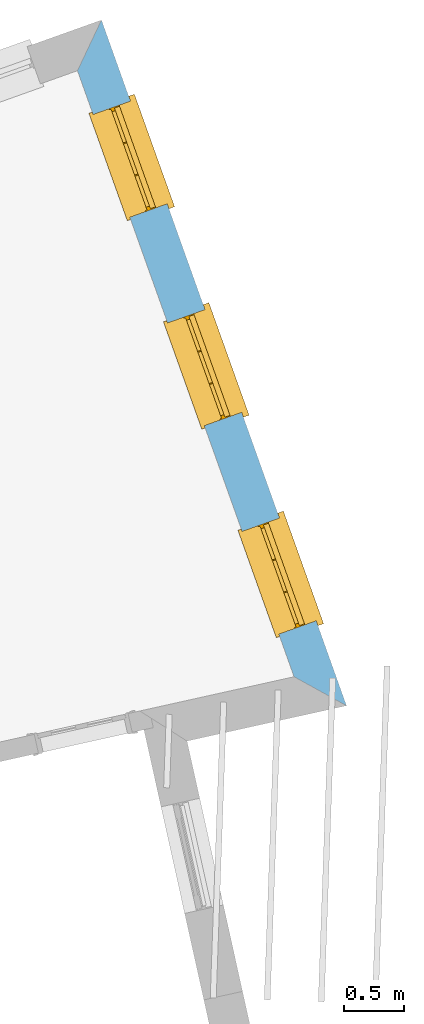
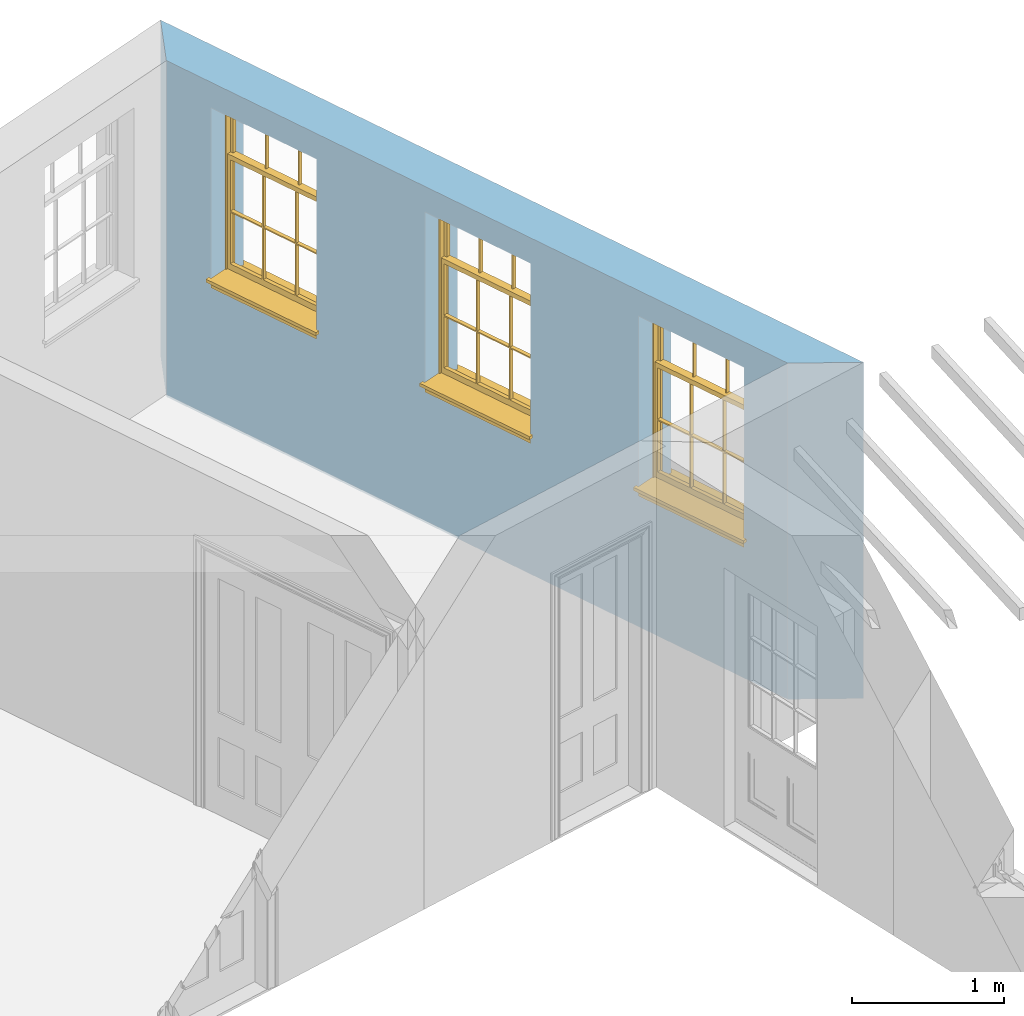
# One storey, part 9 of 11: 3 windows, 3 openings, plus 1 element that does not belong to this part.
"""IFC2X3 building model written with IfcOpenShell, lengths in metres."""

from ifc_helpers import new_model, si_unit, frame, origin, place, context, subcontext, project, spatial, polyline, outline, extrude, faceted_brep, material, layer, layer_set, layer_usage, element, fill, save


model = new_model("IFC2X3")

# Units and contexts
model_context = context("Model", 3, world=origin())
body_context = subcontext(model_context, "Body", "Model", "MODEL_VIEW")
ifc_project = project(units=[si_unit("PLANEANGLEUNIT", "RADIAN"), si_unit("MASSUNIT", "GRAM", prefix="KILO"), si_unit("FORCEUNIT", "NEWTON", prefix="KILO"), si_unit("LENGTHUNIT", "METRE")], contexts=[model_context])

# Site, building, storey
site_placement = place(None, origin())
site = spatial("IfcSite", under=ifc_project, at=site_placement, CompositionType="ELEMENT")
building_placement = place(None, origin())
building = spatial("IfcBuilding", under=site, at=building_placement, Name="Building plot-16", CompositionType="ELEMENT")
storey_placement = place(None, frame((0.0, 0.0, 9.0)))
storey = spatial("IfcBuildingStorey", under=building, at=storey_placement, Name="Floor 2", CompositionType="ELEMENT", Elevation=9.0)

# Wall, openings, windows
ifc_material = material(Name="Masonry")
ifc_layer = layer(ifc_material, 0.33, ventilated=False)
ifc_layer_set = layer_set([ifc_layer], Name="My Wall")
ifc_layer_usage = layer_usage(ifc_layer_set, "AXIS2", "NEGATIVE", 0.08)
wall_placement = place(storey_placement, origin())
wall = element("IfcWallStandardCase", 1, at=wall_placement, inside=storey, material=ifc_layer_usage, Name="exterior", context=body_context, shape_type="SweptSolid", body=[
    extrude(outline(polyline([(97.3810072176828, 35.8023562668068), (97.8176362791509, 35.5611669858636), (95.7767041340643, 41.2723465883469), (95.5770005534573, 40.8505427478087), (97.3810072176828, 35.8023562668068)])), origin(), (0.0, 0.0, 1.0), 2.7),
])
opening_1_placement = place(storey_placement, frame((0.0, 0.0, 1.05)))
opening_1 = element("IfcOpeningElement", 2, at=opening_1_placement, cuts=wall, Name="Opening", ObjectType="Opening", context=body_context, shape_type="SweptSolid", body=[
    extrude(outline(polyline([(97.5651502138981, 36.2677035893733), (97.2589210676294, 37.1246304882249), (96.9481673570568, 37.0135803582594), (97.2543965033255, 36.1566534594077), (97.5651502138981, 36.2677035893733)])), origin(), (0.0, 0.0, 1.0), 1.445),
])
opening_2_placement = place(storey_placement, frame((0.0, 0.0, 1.05)))
opening_2 = element("IfcOpeningElement", 3, at=opening_2_placement, cuts=wall, Name="Opening", ObjectType="Opening", context=body_context, shape_type="SweptSolid", body=[
    extrude(outline(polyline([(96.9446691657534, 38.0040076181098), (96.6384400194846, 38.8609345169614), (96.3276863089121, 38.7498843869959), (96.6339154551808, 37.8929574881442), (96.9446691657534, 38.0040076181098)])), origin(), (0.0, 0.0, 1.0), 1.445),
])
opening_3_placement = place(storey_placement, frame((0.0, 0.0, 1.05)))
opening_3 = element("IfcOpeningElement", 4, at=opening_3_placement, cuts=wall, Name="Opening", ObjectType="Opening", context=body_context, shape_type="SweptSolid", body=[
    extrude(outline(polyline([(96.3241881176086, 39.7403116468463), (96.0179589713399, 40.5972385456979), (95.7072052607673, 40.4861884157324), (96.013434407036, 39.6292615168807), (96.3241881176086, 39.7403116468463)])), origin(), (0.0, 0.0, 1.0), 1.445),
])
window_1_placement = place(storey_placement, frame((97.3297307361916, 36.1835747030357, 1.05), z_axis=(0.0, 0.0, 1.0), x_axis=(-0.306229146268706, 0.856926898851668, 0.0)))
window_1 = element("IfcWindow", 5, at=window_1_placement, inside=storey, Name="kitchen outside window", OverallHeight=1.445, OverallWidth=0.91, context=body_context, shape_type="Brep", held_by="IfcProductRepresentation", body=[
    faceted_brep([(0.876875, -0.105, 0.999097), (0.876875, -0.105, 1.411875), (0.9, -0.105, 1.435), (0.033125, -0.105, 1.411875), (0.033125, -0.105, 0.999097), (0.01, -0.105, 1.435), (0.033125, -0.135, 1.411875), (0.01, -0.135, 1.435), (0.033125, -0.135, 0.999097), (0.876875, -0.135, 1.411875), (0.876875, -0.135, 0.999097), (0.9, -0.135, 1.435), (0.033125, -0.105, 0.960972), (0.01, -0.105, 0.960972), (0.033125, -0.105, 0.548195), (0.876875, -0.105, 0.960972), (0.876875, -0.105, 0.548195), (0.9, -0.105, 0.960972), (0.876875, -0.105, 0.538195), (0.876875, -0.105, 0.125417), (0.9, -0.105, 0.077167), (0.033125, -0.105, 0.125417), (0.033125, -0.105, 0.538195), (0.01, -0.105, 0.077167), (0.9, -0.135, 0.960972), (0.01, -0.135, 0.960972), (-0.0425, -0.25, 0.01), (-0.0425, -0.3, 0.001667), (0.0, -0.25, 0.01), (0.9525, -0.25, 0.01), (0.91, -0.25, 0.01), (0.9525, -0.3, 0.001667), (-0.02, 0.08, 0.077167), (0.0, 0.08, 0.077167), (-0.02, 0.11, 0.077167), (0.0, -0.06, 0.077167), (0.01, -0.06, 0.077167), (0.91, -0.06, 0.077167), (0.91, 0.08, 0.077167), (0.9, -0.06, 0.077167), (0.93, 0.08, 0.077167), (0.93, 0.11, 0.077167), (0.01, -0.105, 0.999097), (0.01, -0.075, 0.999097), (0.9, -0.105, 0.999097), (0.9, -0.075, 0.999097), (0.876875, -0.075, 0.125417), (0.876875, -0.075, 0.538195), (0.9, -0.075, 0.077167), (0.876875, -0.075, 0.548195), (0.876875, -0.075, 0.960972), (0.033125, -0.075, 0.125417), (0.01, -0.075, 0.077167), (0.033125, -0.075, 0.538195), (0.033125, -0.075, 0.960972), (0.033125, -0.075, 0.548195), (-0.02, 0.08, 0.052167), (-0.02, 0.11, 0.052167), (0.93, 0.11, 0.052167), (0.93, 0.08, 0.052167), (0.91, 0.08, 0.052167), (0.0, 0.08, 0.052167), (0.91, -0.15, 0.026667), (0.0, -0.15, 0.026667), (-0.0425, -0.3, -0.123333), (0.9525, -0.3, -0.123333), (-0.0425, -0.25, -0.123333), (0.9525, -0.25, -0.123333), (0.01, -0.06, 1.435), (0.9, -0.06, 1.435), (0.0, -0.06, 1.445), (0.91, -0.06, 1.445), (0.01, -0.15, 0.077167), (0.9, -0.15, 0.077167), (0.592292, -0.105, 0.125417), (0.592292, -0.075, 0.125417), (0.317708, -0.075, 0.125417), (0.317708, -0.105, 0.125417), (0.592292, -0.105, 0.548195), (0.317708, -0.105, 0.548195), (0.317708, -0.105, 0.538195), (0.592292, -0.105, 0.538195), (0.592292, -0.075, 0.548195), (0.317708, -0.075, 0.548195), (0.602292, -0.075, 0.548195), (0.602292, -0.105, 0.548195), (0.317708, -0.075, 0.538195), (0.307708, -0.075, 0.125417), (0.307708, -0.075, 0.538195), (0.602292, -0.075, 0.538195), (0.602292, -0.075, 0.125417), (0.592292, -0.075, 0.538195), (0.307708, -0.075, 0.548195), (0.317708, -0.075, 0.960972), (0.307708, -0.075, 0.960972), (0.602292, -0.075, 0.960972), (0.592292, -0.075, 0.960972), (0.307708, -0.105, 0.538195), (0.307708, -0.105, 0.125417), (0.307708, -0.105, 0.548195), (0.307708, -0.105, 0.960972), (0.592292, -0.105, 0.960972), (0.317708, -0.105, 0.960972), (0.602292, -0.105, 0.960972), (0.602292, -0.105, 0.538195), (0.602292, -0.105, 0.125417), (0.317708, -0.135, 1.411875), (0.307708, -0.135, 1.411875), (0.307708, -0.135, 0.999097), (0.317708, -0.135, 0.999097), (0.602292, -0.135, 1.411875), (0.592292, -0.135, 1.411875), (0.592292, -0.135, 0.999097), (0.602292, -0.135, 0.999097), (0.317708, -0.105, 0.999097), (0.307708, -0.105, 0.999097), (0.307708, -0.105, 1.411875), (0.317708, -0.105, 1.411875), (0.602292, -0.105, 0.999097), (0.592292, -0.105, 0.999097), (0.592292, -0.105, 1.411875), (0.602292, -0.105, 1.411875), (0.91, -0.15, 1.445), (0.9, -0.15, 1.435), (0.01, -0.15, 1.435), (0.0, -0.15, 1.445), (0.91, -0.25, 0.0), (0.0, -0.25, 0.0), (0.91, 0.08, 0.0), (0.0, 0.08, 0.0)], [[[0, 1, 2]], [[3, 4, 5]], [[6, 7, 8]], [[9, 10, 11]], [[12, 13, 14]], [[15, 16, 17]], [[18, 19, 20]], [[21, 22, 23]], [[24, 15, 17]], [[13, 12, 25]], [[26, 27, 28]], [[29, 30, 31]], [[32, 33, 34]], [[35, 36, 33]], [[37, 38, 39]], [[40, 41, 38]], [[42, 4, 43]], [[44, 45, 0]], [[46, 47, 48]], [[49, 50, 45]], [[51, 52, 53]], [[54, 55, 43]], [[38, 33, 36, 39]], [[41, 34, 33, 38]], [[56, 32, 34, 57]], [[57, 34, 41, 58]], [[58, 41, 40, 59]], [[57, 58, 60, 61]], [[52, 48, 39, 36]], [[62, 63, 28, 30]], [[27, 31, 30, 28]], [[27, 64, 65, 31]], [[66, 67, 65, 64]], [[2, 5, 68, 69]], [[68, 70, 71, 69]], [[20, 23, 72, 73]], [[73, 72, 63, 62]], [[74, 75, 76, 77]], [[78, 79, 80, 81]], [[78, 82, 83, 79]], [[16, 49, 84, 85]], [[86, 76, 87, 88]], [[89, 90, 75, 91]], [[92, 88, 53, 55]], [[82, 91, 86, 83]], [[93, 83, 92, 94]], [[95, 84, 82, 96]], [[89, 84, 49, 47]], [[97, 88, 87, 98]], [[22, 53, 88, 97]], [[81, 91, 75, 74]], [[80, 86, 91, 81]], [[77, 76, 86, 80]], [[99, 92, 55, 14]], [[100, 94, 92, 99]], [[101, 96, 82, 78]], [[79, 83, 93, 102]], [[85, 84, 95, 103]], [[104, 89, 47, 18]], [[105, 90, 89, 104]], [[104, 18, 16, 85]], [[80, 97, 98, 77]], [[104, 81, 74, 105]], [[103, 101, 78, 85]], [[99, 14, 22, 97]], [[102, 100, 99, 79]], [[106, 107, 108, 109]], [[110, 111, 112, 113]], [[114, 115, 116, 117]], [[118, 119, 120, 121]], [[107, 116, 115, 108]], [[111, 120, 119, 112]], [[109, 114, 117, 106]], [[113, 118, 121, 110]], [[85, 78, 81, 104]], [[84, 89, 91, 82]], [[83, 86, 88, 92]], [[79, 99, 97, 80]], [[109, 112, 119, 114]], [[102, 93, 96, 101]], [[106, 117, 120, 111]], [[98, 87, 51, 21]], [[6, 3, 116, 107]], [[110, 121, 1, 9]], [[19, 46, 90, 105]], [[26, 66, 64, 27]], [[29, 31, 65, 67]], [[25, 24, 112, 109]], [[11, 7, 106, 111]], [[75, 48, 52, 76]], [[43, 45, 96, 93]], [[45, 43, 114, 119]], [[5, 2, 120, 117]], [[24, 25, 102, 101]], [[42, 5, 4]], [[2, 44, 0]], [[49, 45, 48, 47]], [[52, 43, 55, 53]], [[14, 13, 23, 22]], [[20, 17, 16, 18]], [[24, 11, 10]], [[25, 8, 7]], [[8, 4, 3, 6]], [[9, 1, 0, 10]], [[15, 50, 49, 16]], [[18, 47, 46, 19]], [[21, 51, 53, 22]], [[14, 55, 54, 12]], [[44, 2, 69, 45]], [[68, 5, 42, 43]], [[36, 35, 70, 68]], [[39, 69, 71, 37]], [[62, 122, 123, 73]], [[63, 72, 124, 125]], [[8, 108, 115, 4]], [[113, 10, 0, 118]], [[94, 100, 12, 54]], [[17, 20, 73, 24]], [[72, 23, 13, 25]], [[52, 36, 68, 43]], [[69, 39, 48, 45]], [[11, 24, 73, 123]], [[7, 124, 72, 25]], [[23, 77, 98]], [[98, 21, 23]], [[105, 74, 20]], [[20, 19, 105]], [[20, 74, 77, 23]], [[113, 112, 24]], [[24, 10, 113]], [[25, 109, 108]], [[108, 8, 25]], [[110, 9, 11]], [[11, 111, 110]], [[7, 6, 107]], [[107, 106, 7]], [[5, 117, 116]], [[116, 3, 5]], [[121, 120, 2]], [[2, 1, 121]], [[11, 123, 124, 7]], [[122, 125, 124, 123]], [[43, 93, 94]], [[94, 54, 43]], [[96, 45, 95]], [[50, 95, 45]], [[15, 103, 95, 50]], [[48, 75, 90]], [[90, 46, 48]], [[87, 76, 52]], [[52, 51, 87]], [[103, 15, 24]], [[24, 101, 103]], [[100, 102, 25]], [[25, 12, 100]], [[115, 114, 43]], [[43, 4, 115]], [[118, 0, 45]], [[45, 119, 118]], [[71, 70, 125, 122]], [[70, 35, 63, 125]], [[122, 62, 37, 71]], [[126, 67, 66, 127]], [[60, 58, 59]], [[38, 60, 59, 40]], [[61, 56, 57]], [[32, 56, 61, 33]], [[61, 60, 128, 129]], [[62, 60, 38, 37]], [[126, 128, 60, 62]], [[33, 61, 63, 35]], [[61, 129, 127, 63]], [[128, 126, 127, 129]], [[28, 127, 66, 26]], [[63, 127, 28]], [[29, 67, 126, 30]], [[30, 126, 62]]]),
])
fill(opening_1, window_1)
window_2_placement = place(storey_placement, frame((96.7092496880469, 37.9198787317722, 1.05), z_axis=(0.0, 0.0, 1.0), x_axis=(-0.306229146268706, 0.856926898851668, 0.0)))
window_2 = element("IfcWindow", 6, at=window_2_placement, inside=storey, Name="kitchen outside window", OverallHeight=1.445, OverallWidth=0.91, context=body_context, shape_type="Brep", held_by="IfcProductRepresentation", body=[
    faceted_brep([(0.876875, -0.105, 0.999097), (0.876875, -0.105, 1.411875), (0.9, -0.105, 1.435), (0.033125, -0.105, 1.411875), (0.033125, -0.105, 0.999097), (0.01, -0.105, 1.435), (0.033125, -0.135, 1.411875), (0.01, -0.135, 1.435), (0.033125, -0.135, 0.999097), (0.876875, -0.135, 1.411875), (0.876875, -0.135, 0.999097), (0.9, -0.135, 1.435), (0.033125, -0.105, 0.960972), (0.01, -0.105, 0.960972), (0.033125, -0.105, 0.548195), (0.876875, -0.105, 0.960972), (0.876875, -0.105, 0.548195), (0.9, -0.105, 0.960972), (0.876875, -0.105, 0.538195), (0.876875, -0.105, 0.125417), (0.9, -0.105, 0.077167), (0.033125, -0.105, 0.125417), (0.033125, -0.105, 0.538195), (0.01, -0.105, 0.077167), (0.9, -0.135, 0.960972), (0.01, -0.135, 0.960972), (-0.0425, -0.25, 0.01), (-0.0425, -0.3, 0.001667), (0.0, -0.25, 0.01), (0.9525, -0.25, 0.01), (0.91, -0.25, 0.01), (0.9525, -0.3, 0.001667), (-0.02, 0.08, 0.077167), (0.0, 0.08, 0.077167), (-0.02, 0.11, 0.077167), (0.0, -0.06, 0.077167), (0.01, -0.06, 0.077167), (0.91, -0.06, 0.077167), (0.91, 0.08, 0.077167), (0.9, -0.06, 0.077167), (0.93, 0.08, 0.077167), (0.93, 0.11, 0.077167), (0.01, -0.105, 0.999097), (0.01, -0.075, 0.999097), (0.9, -0.105, 0.999097), (0.9, -0.075, 0.999097), (0.876875, -0.075, 0.125417), (0.876875, -0.075, 0.538195), (0.9, -0.075, 0.077167), (0.876875, -0.075, 0.548195), (0.876875, -0.075, 0.960972), (0.033125, -0.075, 0.125417), (0.01, -0.075, 0.077167), (0.033125, -0.075, 0.538195), (0.033125, -0.075, 0.960972), (0.033125, -0.075, 0.548195), (-0.02, 0.08, 0.052167), (-0.02, 0.11, 0.052167), (0.93, 0.11, 0.052167), (0.93, 0.08, 0.052167), (0.91, 0.08, 0.052167), (0.0, 0.08, 0.052167), (0.91, -0.15, 0.026667), (0.0, -0.15, 0.026667), (-0.0425, -0.3, -0.123333), (0.9525, -0.3, -0.123333), (-0.0425, -0.25, -0.123333), (0.9525, -0.25, -0.123333), (0.01, -0.06, 1.435), (0.9, -0.06, 1.435), (0.0, -0.06, 1.445), (0.91, -0.06, 1.445), (0.01, -0.15, 0.077167), (0.9, -0.15, 0.077167), (0.592292, -0.105, 0.125417), (0.592292, -0.075, 0.125417), (0.317708, -0.075, 0.125417), (0.317708, -0.105, 0.125417), (0.592292, -0.105, 0.548195), (0.317708, -0.105, 0.548195), (0.317708, -0.105, 0.538195), (0.592292, -0.105, 0.538195), (0.592292, -0.075, 0.548195), (0.317708, -0.075, 0.548195), (0.602292, -0.075, 0.548195), (0.602292, -0.105, 0.548195), (0.317708, -0.075, 0.538195), (0.307708, -0.075, 0.125417), (0.307708, -0.075, 0.538195), (0.602292, -0.075, 0.538195), (0.602292, -0.075, 0.125417), (0.592292, -0.075, 0.538195), (0.307708, -0.075, 0.548195), (0.317708, -0.075, 0.960972), (0.307708, -0.075, 0.960972), (0.602292, -0.075, 0.960972), (0.592292, -0.075, 0.960972), (0.307708, -0.105, 0.538195), (0.307708, -0.105, 0.125417), (0.307708, -0.105, 0.548195), (0.307708, -0.105, 0.960972), (0.592292, -0.105, 0.960972), (0.317708, -0.105, 0.960972), (0.602292, -0.105, 0.960972), (0.602292, -0.105, 0.538195), (0.602292, -0.105, 0.125417), (0.317708, -0.135, 1.411875), (0.307708, -0.135, 1.411875), (0.307708, -0.135, 0.999097), (0.317708, -0.135, 0.999097), (0.602292, -0.135, 1.411875), (0.592292, -0.135, 1.411875), (0.592292, -0.135, 0.999097), (0.602292, -0.135, 0.999097), (0.317708, -0.105, 0.999097), (0.307708, -0.105, 0.999097), (0.307708, -0.105, 1.411875), (0.317708, -0.105, 1.411875), (0.602292, -0.105, 0.999097), (0.592292, -0.105, 0.999097), (0.592292, -0.105, 1.411875), (0.602292, -0.105, 1.411875), (0.91, -0.15, 1.445), (0.9, -0.15, 1.435), (0.01, -0.15, 1.435), (0.0, -0.15, 1.445), (0.91, -0.25, 0.0), (0.0, -0.25, 0.0), (0.91, 0.08, 0.0), (0.0, 0.08, 0.0)], [[[0, 1, 2]], [[3, 4, 5]], [[6, 7, 8]], [[9, 10, 11]], [[12, 13, 14]], [[15, 16, 17]], [[18, 19, 20]], [[21, 22, 23]], [[24, 15, 17]], [[13, 12, 25]], [[26, 27, 28]], [[29, 30, 31]], [[32, 33, 34]], [[35, 36, 33]], [[37, 38, 39]], [[40, 41, 38]], [[42, 4, 43]], [[44, 45, 0]], [[46, 47, 48]], [[49, 50, 45]], [[51, 52, 53]], [[54, 55, 43]], [[38, 33, 36, 39]], [[41, 34, 33, 38]], [[56, 32, 34, 57]], [[57, 34, 41, 58]], [[58, 41, 40, 59]], [[57, 58, 60, 61]], [[52, 48, 39, 36]], [[62, 63, 28, 30]], [[27, 31, 30, 28]], [[27, 64, 65, 31]], [[66, 67, 65, 64]], [[2, 5, 68, 69]], [[68, 70, 71, 69]], [[20, 23, 72, 73]], [[73, 72, 63, 62]], [[74, 75, 76, 77]], [[78, 79, 80, 81]], [[78, 82, 83, 79]], [[16, 49, 84, 85]], [[86, 76, 87, 88]], [[89, 90, 75, 91]], [[92, 88, 53, 55]], [[82, 91, 86, 83]], [[93, 83, 92, 94]], [[95, 84, 82, 96]], [[89, 84, 49, 47]], [[97, 88, 87, 98]], [[22, 53, 88, 97]], [[81, 91, 75, 74]], [[80, 86, 91, 81]], [[77, 76, 86, 80]], [[99, 92, 55, 14]], [[100, 94, 92, 99]], [[101, 96, 82, 78]], [[79, 83, 93, 102]], [[85, 84, 95, 103]], [[104, 89, 47, 18]], [[105, 90, 89, 104]], [[104, 18, 16, 85]], [[80, 97, 98, 77]], [[104, 81, 74, 105]], [[103, 101, 78, 85]], [[99, 14, 22, 97]], [[102, 100, 99, 79]], [[106, 107, 108, 109]], [[110, 111, 112, 113]], [[114, 115, 116, 117]], [[118, 119, 120, 121]], [[107, 116, 115, 108]], [[111, 120, 119, 112]], [[109, 114, 117, 106]], [[113, 118, 121, 110]], [[85, 78, 81, 104]], [[84, 89, 91, 82]], [[83, 86, 88, 92]], [[79, 99, 97, 80]], [[109, 112, 119, 114]], [[102, 93, 96, 101]], [[106, 117, 120, 111]], [[98, 87, 51, 21]], [[6, 3, 116, 107]], [[110, 121, 1, 9]], [[19, 46, 90, 105]], [[26, 66, 64, 27]], [[29, 31, 65, 67]], [[25, 24, 112, 109]], [[11, 7, 106, 111]], [[75, 48, 52, 76]], [[43, 45, 96, 93]], [[45, 43, 114, 119]], [[5, 2, 120, 117]], [[24, 25, 102, 101]], [[42, 5, 4]], [[2, 44, 0]], [[49, 45, 48, 47]], [[52, 43, 55, 53]], [[14, 13, 23, 22]], [[20, 17, 16, 18]], [[24, 11, 10]], [[25, 8, 7]], [[8, 4, 3, 6]], [[9, 1, 0, 10]], [[15, 50, 49, 16]], [[18, 47, 46, 19]], [[21, 51, 53, 22]], [[14, 55, 54, 12]], [[44, 2, 69, 45]], [[68, 5, 42, 43]], [[36, 35, 70, 68]], [[39, 69, 71, 37]], [[62, 122, 123, 73]], [[63, 72, 124, 125]], [[8, 108, 115, 4]], [[113, 10, 0, 118]], [[94, 100, 12, 54]], [[17, 20, 73, 24]], [[72, 23, 13, 25]], [[52, 36, 68, 43]], [[69, 39, 48, 45]], [[11, 24, 73, 123]], [[7, 124, 72, 25]], [[23, 77, 98]], [[98, 21, 23]], [[105, 74, 20]], [[20, 19, 105]], [[20, 74, 77, 23]], [[113, 112, 24]], [[24, 10, 113]], [[25, 109, 108]], [[108, 8, 25]], [[110, 9, 11]], [[11, 111, 110]], [[7, 6, 107]], [[107, 106, 7]], [[5, 117, 116]], [[116, 3, 5]], [[121, 120, 2]], [[2, 1, 121]], [[11, 123, 124, 7]], [[122, 125, 124, 123]], [[43, 93, 94]], [[94, 54, 43]], [[96, 45, 95]], [[50, 95, 45]], [[15, 103, 95, 50]], [[48, 75, 90]], [[90, 46, 48]], [[87, 76, 52]], [[52, 51, 87]], [[103, 15, 24]], [[24, 101, 103]], [[100, 102, 25]], [[25, 12, 100]], [[115, 114, 43]], [[43, 4, 115]], [[118, 0, 45]], [[45, 119, 118]], [[71, 70, 125, 122]], [[70, 35, 63, 125]], [[122, 62, 37, 71]], [[126, 67, 66, 127]], [[60, 58, 59]], [[38, 60, 59, 40]], [[61, 56, 57]], [[32, 56, 61, 33]], [[61, 60, 128, 129]], [[62, 60, 38, 37]], [[126, 128, 60, 62]], [[33, 61, 63, 35]], [[61, 129, 127, 63]], [[128, 126, 127, 129]], [[28, 127, 66, 26]], [[63, 127, 28]], [[29, 67, 126, 30]], [[30, 126, 62]]]),
])
fill(opening_2, window_2)
window_3_placement = place(storey_placement, frame((96.0887686399021, 39.6561827605087, 1.05), z_axis=(0.0, 0.0, 1.0), x_axis=(-0.306229146268706, 0.856926898851668, 0.0)))
window_3 = element("IfcWindow", 7, at=window_3_placement, inside=storey, Name="kitchen outside window", OverallHeight=1.445, OverallWidth=0.91, context=body_context, shape_type="Brep", held_by="IfcProductRepresentation", body=[
    faceted_brep([(0.876875, -0.105, 0.999097), (0.876875, -0.105, 1.411875), (0.9, -0.105, 1.435), (0.033125, -0.105, 1.411875), (0.033125, -0.105, 0.999097), (0.01, -0.105, 1.435), (0.033125, -0.135, 1.411875), (0.01, -0.135, 1.435), (0.033125, -0.135, 0.999097), (0.876875, -0.135, 1.411875), (0.876875, -0.135, 0.999097), (0.9, -0.135, 1.435), (0.033125, -0.105, 0.960972), (0.01, -0.105, 0.960972), (0.033125, -0.105, 0.548195), (0.876875, -0.105, 0.960972), (0.876875, -0.105, 0.548195), (0.9, -0.105, 0.960972), (0.876875, -0.105, 0.538195), (0.876875, -0.105, 0.125417), (0.9, -0.105, 0.077167), (0.033125, -0.105, 0.125417), (0.033125, -0.105, 0.538195), (0.01, -0.105, 0.077167), (0.9, -0.135, 0.960972), (0.01, -0.135, 0.960972), (-0.0425, -0.25, 0.01), (-0.0425, -0.3, 0.001667), (0.0, -0.25, 0.01), (0.9525, -0.25, 0.01), (0.91, -0.25, 0.01), (0.9525, -0.3, 0.001667), (-0.02, 0.08, 0.077167), (0.0, 0.08, 0.077167), (-0.02, 0.11, 0.077167), (0.0, -0.06, 0.077167), (0.01, -0.06, 0.077167), (0.91, -0.06, 0.077167), (0.91, 0.08, 0.077167), (0.9, -0.06, 0.077167), (0.93, 0.08, 0.077167), (0.93, 0.11, 0.077167), (0.01, -0.105, 0.999097), (0.01, -0.075, 0.999097), (0.9, -0.105, 0.999097), (0.9, -0.075, 0.999097), (0.876875, -0.075, 0.125417), (0.876875, -0.075, 0.538195), (0.9, -0.075, 0.077167), (0.876875, -0.075, 0.548195), (0.876875, -0.075, 0.960972), (0.033125, -0.075, 0.125417), (0.01, -0.075, 0.077167), (0.033125, -0.075, 0.538195), (0.033125, -0.075, 0.960972), (0.033125, -0.075, 0.548195), (-0.02, 0.08, 0.052167), (-0.02, 0.11, 0.052167), (0.93, 0.11, 0.052167), (0.93, 0.08, 0.052167), (0.91, 0.08, 0.052167), (0.0, 0.08, 0.052167), (0.91, -0.15, 0.026667), (0.0, -0.15, 0.026667), (-0.0425, -0.3, -0.123333), (0.9525, -0.3, -0.123333), (-0.0425, -0.25, -0.123333), (0.9525, -0.25, -0.123333), (0.01, -0.06, 1.435), (0.9, -0.06, 1.435), (0.0, -0.06, 1.445), (0.91, -0.06, 1.445), (0.01, -0.15, 0.077167), (0.9, -0.15, 0.077167), (0.592292, -0.105, 0.125417), (0.592292, -0.075, 0.125417), (0.317708, -0.075, 0.125417), (0.317708, -0.105, 0.125417), (0.592292, -0.105, 0.548195), (0.317708, -0.105, 0.548195), (0.317708, -0.105, 0.538195), (0.592292, -0.105, 0.538195), (0.592292, -0.075, 0.548195), (0.317708, -0.075, 0.548195), (0.602292, -0.075, 0.548195), (0.602292, -0.105, 0.548195), (0.317708, -0.075, 0.538195), (0.307708, -0.075, 0.125417), (0.307708, -0.075, 0.538195), (0.602292, -0.075, 0.538195), (0.602292, -0.075, 0.125417), (0.592292, -0.075, 0.538195), (0.307708, -0.075, 0.548195), (0.317708, -0.075, 0.960972), (0.307708, -0.075, 0.960972), (0.602292, -0.075, 0.960972), (0.592292, -0.075, 0.960972), (0.307708, -0.105, 0.538195), (0.307708, -0.105, 0.125417), (0.307708, -0.105, 0.548195), (0.307708, -0.105, 0.960972), (0.592292, -0.105, 0.960972), (0.317708, -0.105, 0.960972), (0.602292, -0.105, 0.960972), (0.602292, -0.105, 0.538195), (0.602292, -0.105, 0.125417), (0.317708, -0.135, 1.411875), (0.307708, -0.135, 1.411875), (0.307708, -0.135, 0.999097), (0.317708, -0.135, 0.999097), (0.602292, -0.135, 1.411875), (0.592292, -0.135, 1.411875), (0.592292, -0.135, 0.999097), (0.602292, -0.135, 0.999097), (0.317708, -0.105, 0.999097), (0.307708, -0.105, 0.999097), (0.307708, -0.105, 1.411875), (0.317708, -0.105, 1.411875), (0.602292, -0.105, 0.999097), (0.592292, -0.105, 0.999097), (0.592292, -0.105, 1.411875), (0.602292, -0.105, 1.411875), (0.91, -0.15, 1.445), (0.9, -0.15, 1.435), (0.01, -0.15, 1.435), (0.0, -0.15, 1.445), (0.91, -0.25, 0.0), (0.0, -0.25, 0.0), (0.91, 0.08, 0.0), (0.0, 0.08, 0.0)], [[[0, 1, 2]], [[3, 4, 5]], [[6, 7, 8]], [[9, 10, 11]], [[12, 13, 14]], [[15, 16, 17]], [[18, 19, 20]], [[21, 22, 23]], [[24, 15, 17]], [[13, 12, 25]], [[26, 27, 28]], [[29, 30, 31]], [[32, 33, 34]], [[35, 36, 33]], [[37, 38, 39]], [[40, 41, 38]], [[42, 4, 43]], [[44, 45, 0]], [[46, 47, 48]], [[49, 50, 45]], [[51, 52, 53]], [[54, 55, 43]], [[38, 33, 36, 39]], [[41, 34, 33, 38]], [[56, 32, 34, 57]], [[57, 34, 41, 58]], [[58, 41, 40, 59]], [[57, 58, 60, 61]], [[52, 48, 39, 36]], [[62, 63, 28, 30]], [[27, 31, 30, 28]], [[27, 64, 65, 31]], [[66, 67, 65, 64]], [[2, 5, 68, 69]], [[68, 70, 71, 69]], [[20, 23, 72, 73]], [[73, 72, 63, 62]], [[74, 75, 76, 77]], [[78, 79, 80, 81]], [[78, 82, 83, 79]], [[16, 49, 84, 85]], [[86, 76, 87, 88]], [[89, 90, 75, 91]], [[92, 88, 53, 55]], [[82, 91, 86, 83]], [[93, 83, 92, 94]], [[95, 84, 82, 96]], [[89, 84, 49, 47]], [[97, 88, 87, 98]], [[22, 53, 88, 97]], [[81, 91, 75, 74]], [[80, 86, 91, 81]], [[77, 76, 86, 80]], [[99, 92, 55, 14]], [[100, 94, 92, 99]], [[101, 96, 82, 78]], [[79, 83, 93, 102]], [[85, 84, 95, 103]], [[104, 89, 47, 18]], [[105, 90, 89, 104]], [[104, 18, 16, 85]], [[80, 97, 98, 77]], [[104, 81, 74, 105]], [[103, 101, 78, 85]], [[99, 14, 22, 97]], [[102, 100, 99, 79]], [[106, 107, 108, 109]], [[110, 111, 112, 113]], [[114, 115, 116, 117]], [[118, 119, 120, 121]], [[107, 116, 115, 108]], [[111, 120, 119, 112]], [[109, 114, 117, 106]], [[113, 118, 121, 110]], [[85, 78, 81, 104]], [[84, 89, 91, 82]], [[83, 86, 88, 92]], [[79, 99, 97, 80]], [[109, 112, 119, 114]], [[102, 93, 96, 101]], [[106, 117, 120, 111]], [[98, 87, 51, 21]], [[6, 3, 116, 107]], [[110, 121, 1, 9]], [[19, 46, 90, 105]], [[26, 66, 64, 27]], [[29, 31, 65, 67]], [[25, 24, 112, 109]], [[11, 7, 106, 111]], [[75, 48, 52, 76]], [[43, 45, 96, 93]], [[45, 43, 114, 119]], [[5, 2, 120, 117]], [[24, 25, 102, 101]], [[42, 5, 4]], [[2, 44, 0]], [[49, 45, 48, 47]], [[52, 43, 55, 53]], [[14, 13, 23, 22]], [[20, 17, 16, 18]], [[24, 11, 10]], [[25, 8, 7]], [[8, 4, 3, 6]], [[9, 1, 0, 10]], [[15, 50, 49, 16]], [[18, 47, 46, 19]], [[21, 51, 53, 22]], [[14, 55, 54, 12]], [[44, 2, 69, 45]], [[68, 5, 42, 43]], [[36, 35, 70, 68]], [[39, 69, 71, 37]], [[62, 122, 123, 73]], [[63, 72, 124, 125]], [[8, 108, 115, 4]], [[113, 10, 0, 118]], [[94, 100, 12, 54]], [[17, 20, 73, 24]], [[72, 23, 13, 25]], [[52, 36, 68, 43]], [[69, 39, 48, 45]], [[11, 24, 73, 123]], [[7, 124, 72, 25]], [[23, 77, 98]], [[98, 21, 23]], [[105, 74, 20]], [[20, 19, 105]], [[20, 74, 77, 23]], [[113, 112, 24]], [[24, 10, 113]], [[25, 109, 108]], [[108, 8, 25]], [[110, 9, 11]], [[11, 111, 110]], [[7, 6, 107]], [[107, 106, 7]], [[5, 117, 116]], [[116, 3, 5]], [[121, 120, 2]], [[2, 1, 121]], [[11, 123, 124, 7]], [[122, 125, 124, 123]], [[43, 93, 94]], [[94, 54, 43]], [[96, 45, 95]], [[50, 95, 45]], [[15, 103, 95, 50]], [[48, 75, 90]], [[90, 46, 48]], [[87, 76, 52]], [[52, 51, 87]], [[103, 15, 24]], [[24, 101, 103]], [[100, 102, 25]], [[25, 12, 100]], [[115, 114, 43]], [[43, 4, 115]], [[118, 0, 45]], [[45, 119, 118]], [[71, 70, 125, 122]], [[70, 35, 63, 125]], [[122, 62, 37, 71]], [[126, 67, 66, 127]], [[60, 58, 59]], [[38, 60, 59, 40]], [[61, 56, 57]], [[32, 56, 61, 33]], [[61, 60, 128, 129]], [[62, 60, 38, 37]], [[126, 128, 60, 62]], [[33, 61, 63, 35]], [[61, 129, 127, 63]], [[128, 126, 127, 129]], [[28, 127, 66, 26]], [[63, 127, 28]], [[29, 67, 126, 30]], [[30, 126, 62]]]),
])
fill(opening_3, window_3)

save(model, "model.ifc")
